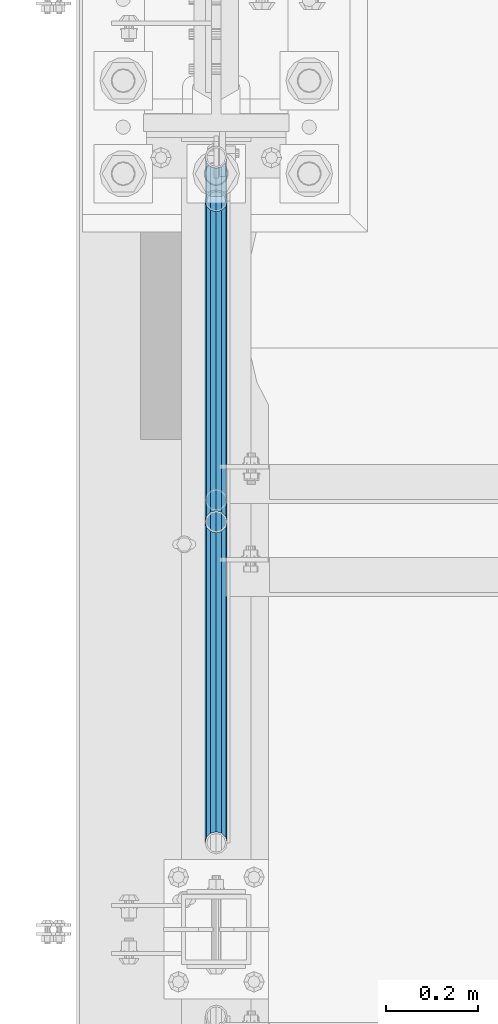
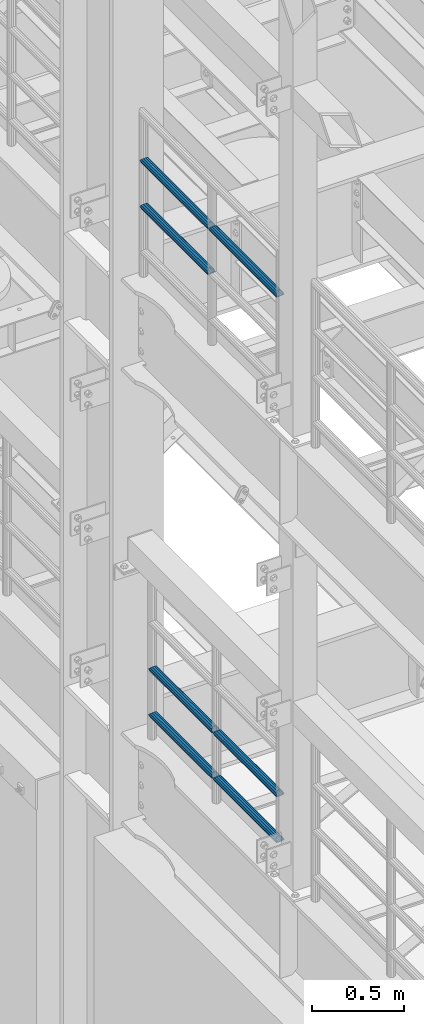
# One storey, part 1285 of 1876: 7 beams, 2 elements without a shape of their own.
"""IFC2X3 building model written with IfcOpenShell, lengths in millimetres."""

from ifc_helpers import new_model, si_unit, frame, origin_with_axes, place, context, subcontext, project, spatial, faceted_brep, material, type_object, element, aggregate, save


model = new_model("IFC2X3")

# Units and contexts
model_context = context("Model", 3, precision=1e-05, world=origin_with_axes())
body_context = subcontext(model_context, "Body", "Model", "MODEL_VIEW")
ifc_project = project(units=[si_unit("LENGTHUNIT", "METRE", prefix="MILLI"), si_unit("AREAUNIT", "SQUARE_METRE"), si_unit("VOLUMEUNIT", "CUBIC_METRE"), si_unit("MASSUNIT", "GRAM", prefix="KILO"), si_unit("TIMEUNIT", "SECOND"), si_unit("PLANEANGLEUNIT", "RADIAN"), si_unit("SOLIDANGLEUNIT", "STERADIAN"), si_unit("THERMODYNAMICTEMPERATUREUNIT", "DEGREE_CELSIUS"), si_unit("LUMINOUSINTENSITYUNIT", "LUMEN")], contexts=[model_context])

# Site, building, storey
site_placement = place(None, origin_with_axes())
site = spatial("IfcSite", under=ifc_project, at=site_placement, CompositionType="ELEMENT")
building_placement = place(site_placement, origin_with_axes())
building = spatial("IfcBuilding", under=site, at=building_placement, Name="Undefined", CompositionType="ELEMENT")
storey_placement = place(building_placement, origin_with_axes())
storey = spatial("IfcBuildingStorey", under=building, at=storey_placement, Name="Undefined", CompositionType="ELEMENT", Elevation=0.0)

# Assembly, beams
assembly_1_placement = place(storey_placement, origin_with_axes())
assembly_1 = element("IfcElementAssembly", 1, at=assembly_1_placement, inside=storey, Name="RAIL", AssemblyPlace="NOTDEFINED", PredefinedType="RIGID_FRAME")
ifc_material = material()
beam_type = type_object("IfcBeamType", Name="PIPE1-1/2SCH40", PredefinedType="NOTDEFINED")
beam_1_placement = place(assembly_1_placement, frame((-1.81898940354586e-12, 6526.2125, 8620.125), z_axis=(0.0, 0.0, -1.0), x_axis=(0.0, 1.0, 0.0)))
beam_1 = element("IfcBeam", 2, at=beam_1_placement, type_object=beam_type, material=ifc_material, Name="RAIL", ObjectType="PIPE1-1/2SCH40", context=body_context, shape_type="Brep", body=[
    faceted_brep([(0.0, 24.1299999999992, 0.0), (12.0650000000064, 20.8971929933177, -12.0649999999987), (12.0650000000064, 20.8971929933177, 12.0649999999987), (12.0650000000064, -20.8971929933177, 12.0649999999987), (12.0650000000064, -20.8971929933177, -12.0649999999987), (0.0, -24.1299999999992, 0.0), (20.8971929933249, -12.0650000000005, 20.8971929933177), (20.8971929933249, -12.0650000000005, 15.8661214311796), (15.2545715621445, -17.7076214311801, 10.2235000000001), (12.5151929933249, -20.4470000000001, 0.0), (15.2545715621445, -17.7076214311801, -10.2235000000001), (20.8971929933249, -12.0650000000005, -15.8661214311796), (20.8971929933249, -12.0650000000005, -20.8971929933177), (24.1300000000063, 0.0, -20.4470000000001), (24.1300000000063, 0.0, -24.130000000001), (21.3906214311868, -10.2235000000001, -17.7076214311819), (21.3906214311868, 10.2235000000001, -17.7076214311819), (20.8971929933249, 12.0650000000005, -15.8661214311796), (20.8971929933249, 12.0650000000005, -20.8971929933177), (15.2545715621445, 17.7076214311801, -10.2235000000001), (12.5151929933249, 20.4470000000001, 0.0), (15.2545715621445, 17.7076214311801, 10.2235000000001), (20.8971929933249, 12.0650000000005, 15.8661214311796), (20.8971929933249, 12.0650000000005, 20.8971929933177), (21.3906214311868, 10.2235000000001, 17.7076214311819), (24.1300000000064, 0.0, 20.4470000000001), (24.1300000000064, 0.0, 24.130000000001), (21.3906214311868, -10.2235000000001, 17.7076214311819), (748.982500000002, 24.1300000000001, 0.0), (736.917500000002, 20.8971929933186, -12.0649999999987), (728.085307006683, 12.0649999999996, -20.8971929933177), (748.982500000002, -24.1300000000001, 0.0), (736.917500000002, -20.8971929933186, -12.0649999999987), (736.917500000002, -20.8971929933186, 12.0649999999987), (728.085307006683, -12.0649999999996, 20.8971929933177), (728.085307006683, -12.0649999999996, -20.8971929933177), (724.852500000002, 0.0, -24.130000000001), (727.591878568821, 10.2235000000001, -17.7076214311819), (724.852500000002, 0.0, -20.4470000000001), (728.085307006683, 12.0649999999996, -15.8661214311796), (728.085307006683, -12.0649999999996, -15.8661214311796), (727.591878568821, -10.2235000000001, -17.7076214311819), (733.727928437864, -17.7076214311801, -10.2235000000001), (736.467307006683, -20.4470000000001, 0.0), (733.727928437864, -17.7076214311801, 10.2235000000001), (728.085307006683, -12.0649999999996, 15.8661214311796), (727.591878568821, -10.2235000000001, 17.7076214311819), (724.852500000002, 0.0, 20.4470000000001), (724.852500000002, 0.0, 24.130000000001), (728.085307006683, 12.0649999999996, 20.8971929933177), (736.917500000002, 20.8971929933186, 12.0649999999987), (728.085307006683, 12.0649999999996, 15.8661214311796), (733.727928437864, 17.7076214311801, 10.2235000000001), (736.467307006683, 20.4470000000001, 0.0), (733.727928437864, 17.7076214311801, -10.2235000000001), (727.591878568821, 10.2235000000001, 17.7076214311819)], [[[0, 1, 2]], [[3, 4, 5]], [[6, 7, 8, 9, 10, 11, 12, 4, 3]], [[13, 14, 12, 11, 15]], [[16, 17, 18, 14, 13]], [[2, 1, 18, 17, 19, 20, 21, 22, 23]], [[23, 22, 24, 25, 26]], [[26, 25, 27, 7, 6]], [[1, 0, 28, 29]], [[18, 1, 29, 30]], [[31, 32, 33]], [[6, 3, 33, 34]], [[3, 5, 31, 33]], [[5, 4, 32, 31]], [[4, 12, 35, 32]], [[12, 14, 36, 35]], [[14, 18, 30, 36]], [[37, 38, 36, 30, 39]], [[40, 35, 36, 38, 41]], [[33, 32, 35, 40, 42, 43, 44, 45, 34]], [[34, 45, 46, 47, 48]], [[26, 6, 34, 48]], [[2, 23, 49, 50]], [[23, 26, 48, 49]], [[0, 2, 50, 28]], [[28, 50, 29]], [[49, 51, 52, 53, 54, 39, 30, 29, 50]], [[48, 47, 55, 51, 49]], [[25, 24, 55, 47]], [[55, 24, 22, 21, 52, 51]], [[21, 20, 53, 52]], [[20, 19, 54, 53]], [[19, 17, 16, 37, 39, 54]], [[16, 13, 38, 37]], [[13, 15, 41, 38]], [[41, 15, 11, 10, 42, 40]], [[10, 9, 43, 42]], [[9, 8, 44, 43]], [[8, 7, 27, 46, 45, 44]], [[27, 25, 47, 46]]]),
])
beam_2_placement = place(assembly_1_placement, frame((-1.81898940354586e-12, 5777.23, 8924.925), z_axis=(0.0, 0.0, -1.0), x_axis=(0.0, 1.0, 0.0)))
beam_2 = element("IfcBeam", 3, at=beam_2_placement, type_object=beam_type, material=ifc_material, Name="RAIL", ObjectType="PIPE1-1/2SCH40", context=body_context, shape_type="Brep", body=[
    faceted_brep([(0.0, 24.1299999999992, 0.0), (12.0650000000064, 20.8971929933177, -12.0649999999987), (12.0650000000064, 20.8971929933177, 12.0649999999987), (12.0650000000064, -20.8971929933177, 12.0649999999987), (12.0650000000064, -20.8971929933177, -12.0649999999987), (0.0, -24.1299999999992, 0.0), (20.8971929933249, -12.0650000000005, 20.8971929933177), (20.8971929933249, -12.0650000000005, 15.8661214311796), (15.2545715621445, -17.7076214311801, 10.2235000000001), (12.5151929933249, -20.4470000000001, 0.0), (15.2545715621445, -17.7076214311801, -10.2235000000001), (20.8971929933249, -12.0650000000005, -15.8661214311796), (20.8971929933249, -12.0650000000005, -20.8971929933177), (24.1300000000063, 0.0, -20.4470000000001), (24.1300000000063, 0.0, -24.130000000001), (21.3906214311868, -10.2235000000001, -17.7076214311819), (21.3906214311868, 10.2235000000001, -17.7076214311819), (20.8971929933249, 12.0650000000005, -15.8661214311796), (20.8971929933249, 12.0650000000005, -20.8971929933177), (15.2545715621445, 17.7076214311801, -10.2235000000001), (12.5151929933249, 20.4470000000001, 0.0), (15.2545715621445, 17.7076214311801, 10.2235000000001), (20.8971929933249, 12.0650000000005, 15.8661214311796), (20.8971929933249, 12.0650000000005, 20.8971929933177), (21.3906214311868, 10.2235000000001, 17.7076214311819), (24.1300000000064, 0.0, 20.4470000000001), (24.1300000000064, 0.0, 24.130000000001), (21.3906214311868, -10.2235000000001, 17.7076214311819), (748.982500000002, 24.1300000000001, 0.0), (736.917500000002, 20.8971929933186, -12.0649999999987), (728.085307006683, 12.0649999999996, -20.8971929933177), (748.982500000002, -24.1300000000001, 0.0), (736.917500000002, -20.8971929933186, -12.0649999999987), (736.917500000002, -20.8971929933186, 12.0649999999987), (728.085307006683, -12.0649999999996, 20.8971929933177), (728.085307006683, -12.0649999999996, -20.8971929933177), (724.852500000002, 0.0, -24.130000000001), (727.591878568821, 10.2235000000001, -17.7076214311819), (724.852500000002, 0.0, -20.4470000000001), (728.085307006683, 12.0649999999996, -15.8661214311796), (728.085307006683, -12.0649999999996, -15.8661214311796), (727.591878568821, -10.2235000000001, -17.7076214311819), (733.727928437864, -17.7076214311801, -10.2235000000001), (736.467307006683, -20.4470000000001, 0.0), (733.727928437864, -17.7076214311801, 10.2235000000001), (728.085307006683, -12.0649999999996, 15.8661214311796), (727.591878568821, -10.2235000000001, 17.7076214311819), (724.852500000002, 0.0, 20.4470000000001), (724.852500000002, 0.0, 24.130000000001), (728.085307006683, 12.0649999999996, 20.8971929933177), (736.917500000002, 20.8971929933186, 12.0649999999987), (728.085307006683, 12.0649999999996, 15.8661214311796), (733.727928437864, 17.7076214311801, 10.2235000000001), (736.467307006683, 20.4470000000001, 0.0), (733.727928437864, 17.7076214311801, -10.2235000000001), (727.591878568821, 10.2235000000001, 17.7076214311819)], [[[0, 1, 2]], [[3, 4, 5]], [[6, 7, 8, 9, 10, 11, 12, 4, 3]], [[13, 14, 12, 11, 15]], [[16, 17, 18, 14, 13]], [[2, 1, 18, 17, 19, 20, 21, 22, 23]], [[23, 22, 24, 25, 26]], [[26, 25, 27, 7, 6]], [[1, 0, 28, 29]], [[18, 1, 29, 30]], [[31, 32, 33]], [[6, 3, 33, 34]], [[3, 5, 31, 33]], [[5, 4, 32, 31]], [[4, 12, 35, 32]], [[12, 14, 36, 35]], [[14, 18, 30, 36]], [[37, 38, 36, 30, 39]], [[40, 35, 36, 38, 41]], [[33, 32, 35, 40, 42, 43, 44, 45, 34]], [[34, 45, 46, 47, 48]], [[26, 6, 34, 48]], [[2, 23, 49, 50]], [[23, 26, 48, 49]], [[0, 2, 50, 28]], [[28, 50, 29]], [[49, 51, 52, 53, 54, 39, 30, 29, 50]], [[48, 47, 55, 51, 49]], [[25, 24, 55, 47]], [[55, 24, 22, 21, 52, 51]], [[21, 20, 53, 52]], [[20, 19, 54, 53]], [[19, 17, 16, 37, 39, 54]], [[16, 13, 38, 37]], [[13, 15, 41, 38]], [[41, 15, 11, 10, 42, 40]], [[10, 9, 43, 42]], [[9, 8, 44, 43]], [[8, 7, 27, 46, 45, 44]], [[27, 25, 47, 46]]]),
])
beam_3_placement = place(assembly_1_placement, frame((-1.81898940354586e-12, 6526.2125, 8924.925), z_axis=(0.0, 0.0, -1.0), x_axis=(0.0, 1.0, 0.0)))
beam_3 = element("IfcBeam", 4, at=beam_3_placement, type_object=beam_type, material=ifc_material, Name="RAIL", ObjectType="PIPE1-1/2SCH40", context=body_context, shape_type="Brep", body=[
    faceted_brep([(0.0, 24.1299999999992, 0.0), (12.0650000000064, 20.8971929933177, -12.0649999999987), (12.0650000000064, 20.8971929933177, 12.0649999999987), (12.0650000000064, -20.8971929933177, 12.0649999999987), (12.0650000000064, -20.8971929933177, -12.0649999999987), (0.0, -24.1299999999992, 0.0), (20.8971929933249, -12.0650000000005, 20.8971929933177), (20.8971929933249, -12.0650000000005, 15.8661214311796), (15.2545715621445, -17.7076214311801, 10.2235000000001), (12.5151929933249, -20.4470000000001, 0.0), (15.2545715621445, -17.7076214311801, -10.2235000000001), (20.8971929933249, -12.0650000000005, -15.8661214311796), (20.8971929933249, -12.0650000000005, -20.8971929933177), (24.1300000000063, 0.0, -20.4470000000001), (24.1300000000063, 0.0, -24.130000000001), (21.3906214311868, -10.2235000000001, -17.7076214311819), (21.3906214311868, 10.2235000000001, -17.7076214311819), (20.8971929933249, 12.0650000000005, -15.8661214311796), (20.8971929933249, 12.0650000000005, -20.8971929933177), (15.2545715621445, 17.7076214311801, -10.2235000000001), (12.5151929933249, 20.4470000000001, 0.0), (15.2545715621445, 17.7076214311801, 10.2235000000001), (20.8971929933249, 12.0650000000005, 15.8661214311796), (20.8971929933249, 12.0650000000005, 20.8971929933177), (21.3906214311868, 10.2235000000001, 17.7076214311819), (24.1300000000064, 0.0, 20.4470000000001), (24.1300000000064, 0.0, 24.130000000001), (21.3906214311868, -10.2235000000001, 17.7076214311819), (748.982500000002, 24.1300000000001, 0.0), (736.917500000002, 20.8971929933186, -12.0649999999987), (728.085307006683, 12.0649999999996, -20.8971929933177), (748.982500000002, -24.1300000000001, 0.0), (736.917500000002, -20.8971929933186, -12.0649999999987), (736.917500000002, -20.8971929933186, 12.0649999999987), (728.085307006683, -12.0649999999996, 20.8971929933177), (728.085307006683, -12.0649999999996, -20.8971929933177), (724.852500000002, 0.0, -24.130000000001), (727.591878568821, 10.2235000000001, -17.7076214311819), (724.852500000002, 0.0, -20.4470000000001), (728.085307006683, 12.0649999999996, -15.8661214311796), (728.085307006683, -12.0649999999996, -15.8661214311796), (727.591878568821, -10.2235000000001, -17.7076214311819), (733.727928437864, -17.7076214311801, -10.2235000000001), (736.467307006683, -20.4470000000001, 0.0), (733.727928437864, -17.7076214311801, 10.2235000000001), (728.085307006683, -12.0649999999996, 15.8661214311796), (727.591878568821, -10.2235000000001, 17.7076214311819), (724.852500000002, 0.0, 20.4470000000001), (724.852500000002, 0.0, 24.130000000001), (728.085307006683, 12.0649999999996, 20.8971929933177), (736.917500000002, 20.8971929933186, 12.0649999999987), (728.085307006683, 12.0649999999996, 15.8661214311796), (733.727928437864, 17.7076214311801, 10.2235000000001), (736.467307006683, 20.4470000000001, 0.0), (733.727928437864, 17.7076214311801, -10.2235000000001), (727.591878568821, 10.2235000000001, 17.7076214311819)], [[[0, 1, 2]], [[3, 4, 5]], [[6, 7, 8, 9, 10, 11, 12, 4, 3]], [[13, 14, 12, 11, 15]], [[16, 17, 18, 14, 13]], [[2, 1, 18, 17, 19, 20, 21, 22, 23]], [[23, 22, 24, 25, 26]], [[26, 25, 27, 7, 6]], [[1, 0, 28, 29]], [[18, 1, 29, 30]], [[31, 32, 33]], [[6, 3, 33, 34]], [[3, 5, 31, 33]], [[5, 4, 32, 31]], [[4, 12, 35, 32]], [[12, 14, 36, 35]], [[14, 18, 30, 36]], [[37, 38, 36, 30, 39]], [[40, 35, 36, 38, 41]], [[33, 32, 35, 40, 42, 43, 44, 45, 34]], [[34, 45, 46, 47, 48]], [[26, 6, 34, 48]], [[2, 23, 49, 50]], [[23, 26, 48, 49]], [[0, 2, 50, 28]], [[28, 50, 29]], [[49, 51, 52, 53, 54, 39, 30, 29, 50]], [[48, 47, 55, 51, 49]], [[25, 24, 55, 47]], [[55, 24, 22, 21, 52, 51]], [[21, 20, 53, 52]], [[20, 19, 54, 53]], [[19, 17, 16, 37, 39, 54]], [[16, 13, 38, 37]], [[13, 15, 41, 38]], [[41, 15, 11, 10, 42, 40]], [[10, 9, 43, 42]], [[9, 8, 44, 43]], [[8, 7, 27, 46, 45, 44]], [[27, 25, 47, 46]]]),
])
aggregate(assembly_1, [beam_1, beam_2, beam_3])

assembly_2_placement = place(storey_placement, origin_with_axes())
assembly_2 = element("IfcElementAssembly", 5, at=assembly_2_placement, inside=storey, Name="RAIL", AssemblyPlace="NOTDEFINED", PredefinedType="RIGID_FRAME")
beam_4_placement = place(assembly_2_placement, frame((7.02584657119587e-11, 6478.5698316807, 5292.73091229414), z_axis=(0.0, -8.42999999986204e-06, 0.999999999964468), x_axis=(0.0, 0.999999999964468, 8.43000000018809e-06)))
beam_4 = element("IfcBeam", 6, at=beam_4_placement, type_object=beam_type, material=ifc_material, Name="RAIL", ObjectType="PIPE1-1/2SCH40", context=body_context, shape_type="Brep", body=[
    faceted_brep([(680.442814874983, -12.0649999999996, 20.8971929933068), (680.44277246305, -12.0649999999277, 15.8661214312397), (679.949359549034, -10.2235000000001, 17.7076214311674), (677.210004073059, 2.72848410531878e-12, 20.4469999999883), (677.210035120749, 2.72848410531878e-12, 24.1299999999883), (679.949359548996, 10.2235000000001, 17.7076214311674), (680.44277246305, 12.0650000000714, 15.866121431096), (680.442814874983, 12.0649999999996, 20.8971929933068), (701.33983170571, 24.1300000000001, -1.45519152283669e-11), (689.27493341323, 20.8971929933186, 12.0649999999878), (689.27472999733, 20.8971929933186, -12.0650000000151), (686.085346327061, 17.7076214311801, 10.2234999999873), (688.824638711873, 20.4470000000001, -1.36424205265939e-11), (686.085173958852, 17.7076214311801, -10.2235000000137), (680.442504960242, 12.0650000000714, -15.8661214311223), (680.442462548309, 12.0649999999996, -20.8971929933323), (679.949060998498, 10.2235000000001, -17.7076214311946), (677.20965933664, 0.0, -20.4470000000147), (677.20962828895, 0.0, -24.1300000000147), (680.442504960242, -12.0649999999277, -15.866121431266), (680.442462548309, -12.0649999999996, -20.8971929933323), (679.949060998536, -10.2235000000001, -17.7076214311946), (701.33983170571, -24.1299999999283, -1.45519152283669e-11), (689.27472999733, -20.8971929933186, -12.0650000000151), (689.27493341323, -20.8971929933186, 12.0649999999878), (686.085173958994, -17.7076214311801, -10.2235000000137), (688.824638712016, -20.4470000000001, -1.36424205265939e-11), (686.085346327204, -17.7076214311801, 10.2234999999873), (12.0648982924813, -20.8971929933186, -12.0650000000005), (20.8970168307269, -12.0649999999996, -20.8971929933195), (0.0, 24.1299999999992, 0.0), (12.0648982924813, 20.8971929933186, -12.0650000000005), (12.065101708381, 20.8971929933186, 12.0650000000005), (20.897369157401, 12.0649999999996, 20.8971929933205), (24.1302034167611, 7.18500814400613e-11, 24.1300000000019), (20.8970168307269, 12.0649999999996, -20.8971929933195), (24.1297965849608, 0.0, -24.130000000001), (24.1298276326506, 0.0, -20.447000000001), (20.8970592426604, -12.0649999999277, -15.8661214312533), (21.390472156676, -10.2235000000001, -17.7076214311819), (21.3904721567151, 10.2235000000001, -17.7076214311819), (20.8970592426604, 12.0650000000714, -15.8661214311096), (15.2544853786503, 17.7076214311801, -10.2235000000001), (12.5151929933249, 20.4470000000001, 0.0), (15.2546577468602, 17.7076214311801, 10.223500000001), (20.8973267454676, 12.0650000000714, 15.8661214311096), (21.3907707072121, 10.2235000000001, 17.7076214311819), (24.1301723690713, 7.18500814400613e-11, 20.447000000001), (21.390770707173, -10.2235000000001, 17.7076214311819), (20.8973267454676, -12.0649999999277, 15.8661214312533), (20.897369157401, -12.0649999999996, 20.8971929933205), (12.065101708381, -20.8971929933186, 12.0650000000005), (0.0, -24.1299999999992, 0.0), (15.2546577467156, -17.7076214311801, 10.223500000001), (12.5151929933249, -20.4470000000001, 0.0), (15.2544853785057, -17.7076214311801, -10.2235000000001)], [[[0, 1, 2, 3, 4]], [[4, 3, 5, 6, 7]], [[8, 9, 10]], [[7, 6, 11, 12, 13, 14, 15, 10, 9]], [[16, 17, 18, 15, 14]], [[19, 20, 18, 17, 21]], [[22, 23, 24]], [[24, 23, 20, 19, 25, 26, 27, 1, 0]], [[28, 29, 20, 23]], [[30, 31, 32]], [[33, 34, 4, 7]], [[32, 33, 7, 9]], [[30, 32, 9, 8]], [[31, 30, 8, 10]], [[35, 31, 10, 15]], [[36, 35, 15, 18]], [[29, 36, 18, 20]], [[37, 36, 29, 38, 39]], [[40, 41, 35, 36, 37]], [[32, 31, 35, 41, 42, 43, 44, 45, 33]], [[33, 45, 46, 47, 34]], [[34, 47, 48, 49, 50]], [[34, 50, 0, 4]], [[50, 51, 24, 0]], [[51, 52, 22, 24]], [[52, 28, 23, 22]], [[51, 28, 52]], [[50, 49, 53, 54, 55, 38, 29, 28, 51]], [[55, 54, 26, 25]], [[21, 39, 38, 55, 25, 19]], [[37, 39, 21, 17]], [[40, 37, 17, 16]], [[42, 41, 40, 16, 14, 13]], [[43, 42, 13, 12]], [[44, 43, 12, 11]], [[5, 46, 45, 44, 11, 6]], [[47, 46, 5, 3]], [[48, 47, 3, 2]], [[53, 49, 48, 2, 1, 27]], [[54, 53, 27, 26]]]),
])
beam_5_placement = place(assembly_2_placement, frame((1.71398992221405e-10, 5777.23, 5292.72499999952), z_axis=(0.0, -8.42999999986204e-06, 0.999999999964468), x_axis=(0.0, 0.999999999964468, 8.43000000018809e-06)))
beam_5 = element("IfcBeam", 7, at=beam_5_placement, type_object=beam_type, material=ifc_material, Name="RAIL", ObjectType="PIPE1-1/2SCH40", context=body_context, shape_type="Brep", body=[
    faceted_brep([(680.442814874983, -12.0649999999996, 20.8971929933068), (680.44277246305, -12.0649999999277, 15.8661214312397), (679.949359549034, -10.2235000000001, 17.7076214311674), (677.210004073059, 2.72848410531878e-12, 20.4469999999883), (677.210035120749, 2.72848410531878e-12, 24.1299999999883), (679.949359548996, 10.2235000000001, 17.7076214311674), (680.44277246305, 12.0650000000714, 15.866121431096), (680.442814874983, 12.0649999999996, 20.8971929933068), (701.33983170571, 24.1300000000001, -1.45519152283669e-11), (689.27493341323, 20.8971929933186, 12.0649999999878), (689.27472999733, 20.8971929933186, -12.0650000000151), (686.085346327061, 17.7076214311801, 10.2234999999873), (688.824638711873, 20.4470000000001, -1.36424205265939e-11), (686.085173958852, 17.7076214311801, -10.2235000000137), (680.442504960242, 12.0650000000714, -15.8661214311223), (680.442462548309, 12.0649999999996, -20.8971929933323), (679.949060998498, 10.2235000000001, -17.7076214311946), (677.20965933664, 0.0, -20.4470000000147), (677.20962828895, 0.0, -24.1300000000147), (680.442504960242, -12.0649999999277, -15.866121431266), (680.442462548309, -12.0649999999996, -20.8971929933323), (679.949060998536, -10.2235000000001, -17.7076214311946), (701.33983170571, -24.1299999999283, -1.45519152283669e-11), (689.27472999733, -20.8971929933186, -12.0650000000151), (689.27493341323, -20.8971929933186, 12.0649999999878), (686.085173958994, -17.7076214311801, -10.2235000000137), (688.824638712016, -20.4470000000001, -1.36424205265939e-11), (686.085346327204, -17.7076214311801, 10.2234999999873), (12.0648982924813, -20.8971929933186, -12.0650000000005), (20.8970168307269, -12.0649999999996, -20.8971929933195), (0.0, 24.1299999999992, 0.0), (12.0648982924813, 20.8971929933186, -12.0650000000005), (12.065101708381, 20.8971929933186, 12.0650000000005), (20.897369157401, 12.0649999999996, 20.8971929933205), (24.1302034167611, 7.18500814400613e-11, 24.1300000000019), (20.8970168307269, 12.0649999999996, -20.8971929933195), (24.1297965849608, 0.0, -24.130000000001), (24.1298276326506, 0.0, -20.447000000001), (20.8970592426604, -12.0649999999277, -15.8661214312533), (21.390472156676, -10.2235000000001, -17.7076214311819), (21.3904721567151, 10.2235000000001, -17.7076214311819), (20.8970592426604, 12.0650000000714, -15.8661214311096), (15.2544853786503, 17.7076214311801, -10.2235000000001), (12.5151929933249, 20.4470000000001, 0.0), (15.2546577468602, 17.7076214311801, 10.223500000001), (20.8973267454676, 12.0650000000714, 15.8661214311096), (21.3907707072121, 10.2235000000001, 17.7076214311819), (24.1301723690713, 7.18500814400613e-11, 20.447000000001), (21.390770707173, -10.2235000000001, 17.7076214311819), (20.8973267454676, -12.0649999999277, 15.8661214312533), (20.897369157401, -12.0649999999996, 20.8971929933205), (12.065101708381, -20.8971929933186, 12.0650000000005), (0.0, -24.1299999999992, 0.0), (15.2546577467156, -17.7076214311801, 10.223500000001), (12.5151929933249, -20.4470000000001, 0.0), (15.2544853785057, -17.7076214311801, -10.2235000000001)], [[[0, 1, 2, 3, 4]], [[4, 3, 5, 6, 7]], [[8, 9, 10]], [[7, 6, 11, 12, 13, 14, 15, 10, 9]], [[16, 17, 18, 15, 14]], [[19, 20, 18, 17, 21]], [[22, 23, 24]], [[24, 23, 20, 19, 25, 26, 27, 1, 0]], [[28, 29, 20, 23]], [[30, 31, 32]], [[33, 34, 4, 7]], [[32, 33, 7, 9]], [[30, 32, 9, 8]], [[31, 30, 8, 10]], [[35, 31, 10, 15]], [[36, 35, 15, 18]], [[29, 36, 18, 20]], [[37, 36, 29, 38, 39]], [[40, 41, 35, 36, 37]], [[32, 31, 35, 41, 42, 43, 44, 45, 33]], [[33, 45, 46, 47, 34]], [[34, 47, 48, 49, 50]], [[34, 50, 0, 4]], [[50, 51, 24, 0]], [[51, 52, 22, 24]], [[52, 28, 23, 22]], [[51, 28, 52]], [[50, 49, 53, 54, 55, 38, 29, 28, 51]], [[55, 54, 26, 25]], [[21, 39, 38, 55, 25, 19]], [[37, 39, 21, 17]], [[40, 37, 17, 16]], [[42, 41, 40, 16, 14, 13]], [[43, 42, 13, 12]], [[44, 43, 12, 11]], [[5, 46, 45, 44, 11, 6]], [[47, 46, 5, 3]], [[48, 47, 3, 2]], [[53, 49, 48, 2, 1, 27]], [[54, 53, 27, 26]]]),
])
beam_6_placement = place(assembly_2_placement, frame((3.1513991416432e-10, 7179.9096633614, 5597.53682459919), z_axis=(0.0, 7.91400000045761e-06, -0.999999999968684), x_axis=(0.0, -0.999999999968684, -7.91400000071008e-06)))
beam_6 = element("IfcBeam", 8, at=beam_6_placement, type_object=beam_type, material=ifc_material, Name="RAIL", ObjectType="PIPE1-1/2SCH40", context=body_context, shape_type="Brep", body=[
    faceted_brep([(0.0, 24.1299999999992, 0.0), (12.0648982924813, 20.8971929933186, -12.0650000000005), (12.065101708381, 20.8971929933186, 12.0650000000005), (12.065101708381, -20.8971929933186, 12.0650000000005), (12.0648982924813, -20.8971929933186, -12.0650000000005), (0.0, -24.1299999999992, 0.0), (20.897369157401, -12.0649999999996, 20.8971929933205), (20.8973267454676, -12.0649999999277, 15.8661214312533), (15.2546577467156, -17.7076214311801, 10.223500000001), (12.5151929933249, -20.4470000000001, 0.0), (15.2544853785057, -17.7076214311801, -10.2235000000001), (20.8970592426604, -12.0649999999277, -15.8661214312533), (20.8970168307269, -12.0649999999996, -20.8971929933195), (24.1298276326506, 0.0, -20.447000000001), (24.1297965849608, 0.0, -24.130000000001), (21.390472156676, -10.2235000000001, -17.7076214311819), (21.3904721567151, 10.2235000000001, -17.7076214311819), (20.8970592426604, 12.0650000000714, -15.8661214311096), (20.8970168307269, 12.0649999999996, -20.8971929933195), (15.2544853786503, 17.7076214311801, -10.2235000000001), (12.5151929933249, 20.4470000000001, 0.0), (15.2546577468602, 17.7076214311801, 10.223500000001), (20.8973267454676, 12.0650000000714, 15.8661214311096), (20.897369157401, 12.0649999999996, 20.8971929933205), (21.3907707072121, 10.2235000000001, 17.7076214311819), (24.1301723690713, 7.18500814400613e-11, 20.447000000001), (24.1302034167611, 7.18500814400613e-11, 24.1300000000019), (21.390770707173, -10.2235000000001, 17.7076214311819), (701.33983170571, 24.1300000000001, -1.45519152283669e-11), (689.27472999733, 20.8971929933186, -12.0650000000151), (680.442462548309, 12.0649999999996, -20.8971929933323), (701.33983170571, -24.1299999999283, -1.45519152283669e-11), (689.27472999733, -20.8971929933186, -12.0650000000151), (689.27493341323, -20.8971929933186, 12.0649999999878), (680.442814874983, -12.0649999999996, 20.8971929933068), (680.442462548309, -12.0649999999996, -20.8971929933323), (677.20962828895, 0.0, -24.1300000000147), (679.949060998498, 10.2235000000001, -17.7076214311946), (677.20965933664, 0.0, -20.4470000000147), (680.442504960242, 12.0650000000714, -15.8661214311223), (680.442504960242, -12.0649999999277, -15.866121431266), (679.949060998536, -10.2235000000001, -17.7076214311946), (686.085173958994, -17.7076214311801, -10.2235000000137), (688.824638712016, -20.4470000000001, -1.36424205265939e-11), (686.085346327204, -17.7076214311801, 10.2234999999873), (680.44277246305, -12.0649999999277, 15.8661214312397), (679.949359549034, -10.2235000000001, 17.7076214311674), (677.210004073059, 2.72848410531878e-12, 20.4469999999883), (677.210035120749, 2.72848410531878e-12, 24.1299999999883), (680.442814874983, 12.0649999999996, 20.8971929933068), (689.27493341323, 20.8971929933186, 12.0649999999878), (680.44277246305, 12.0650000000714, 15.866121431096), (686.085346327061, 17.7076214311801, 10.2234999999873), (688.824638711873, 20.4470000000001, -1.36424205265939e-11), (686.085173958852, 17.7076214311801, -10.2235000000137), (679.949359548996, 10.2235000000001, 17.7076214311674)], [[[0, 1, 2]], [[3, 4, 5]], [[6, 7, 8, 9, 10, 11, 12, 4, 3]], [[13, 14, 12, 11, 15]], [[16, 17, 18, 14, 13]], [[2, 1, 18, 17, 19, 20, 21, 22, 23]], [[23, 22, 24, 25, 26]], [[26, 25, 27, 7, 6]], [[1, 0, 28, 29]], [[18, 1, 29, 30]], [[31, 32, 33]], [[6, 3, 33, 34]], [[3, 5, 31, 33]], [[5, 4, 32, 31]], [[4, 12, 35, 32]], [[12, 14, 36, 35]], [[14, 18, 30, 36]], [[37, 38, 36, 30, 39]], [[40, 35, 36, 38, 41]], [[33, 32, 35, 40, 42, 43, 44, 45, 34]], [[34, 45, 46, 47, 48]], [[26, 6, 34, 48]], [[2, 23, 49, 50]], [[23, 26, 48, 49]], [[0, 2, 50, 28]], [[28, 50, 29]], [[49, 51, 52, 53, 54, 39, 30, 29, 50]], [[48, 47, 55, 51, 49]], [[25, 24, 55, 47]], [[55, 24, 22, 21, 52, 51]], [[21, 20, 53, 52]], [[20, 19, 54, 53]], [[19, 17, 16, 37, 39, 54]], [[16, 13, 38, 37]], [[13, 15, 41, 38]], [[41, 15, 11, 10, 42, 40]], [[10, 9, 43, 42]], [[9, 8, 44, 43]], [[8, 7, 27, 46, 45, 44]], [[27, 25, 47, 46]]]),
])
beam_7_placement = place(assembly_2_placement, frame((7.03721525496803e-11, 6478.5698316807, 5597.53091229414), z_axis=(0.0, 7.91400000045761e-06, -0.999999999968684), x_axis=(0.0, -0.999999999968684, -7.91400000071008e-06)))
beam_7 = element("IfcBeam", 9, at=beam_7_placement, type_object=beam_type, material=ifc_material, Name="RAIL", ObjectType="PIPE1-1/2SCH40", context=body_context, shape_type="Brep", body=[
    faceted_brep([(0.0, 24.1299999999992, 0.0), (12.0648982924813, 20.8971929933186, -12.0650000000005), (12.065101708381, 20.8971929933186, 12.0650000000005), (12.065101708381, -20.8971929933186, 12.0650000000005), (12.0648982924813, -20.8971929933186, -12.0650000000005), (0.0, -24.1299999999992, 0.0), (20.897369157401, -12.0649999999996, 20.8971929933205), (20.8973267454676, -12.0649999999277, 15.8661214312533), (15.2546577467156, -17.7076214311801, 10.223500000001), (12.5151929933249, -20.4470000000001, 0.0), (15.2544853785057, -17.7076214311801, -10.2235000000001), (20.8970592426604, -12.0649999999277, -15.8661214312533), (20.8970168307269, -12.0649999999996, -20.8971929933195), (24.1298276326506, 0.0, -20.447000000001), (24.1297965849608, 0.0, -24.130000000001), (21.390472156676, -10.2235000000001, -17.7076214311819), (21.3904721567151, 10.2235000000001, -17.7076214311819), (20.8970592426604, 12.0650000000714, -15.8661214311096), (20.8970168307269, 12.0649999999996, -20.8971929933195), (15.2544853786503, 17.7076214311801, -10.2235000000001), (12.5151929933249, 20.4470000000001, 0.0), (15.2546577468602, 17.7076214311801, 10.223500000001), (20.8973267454676, 12.0650000000714, 15.8661214311096), (20.897369157401, 12.0649999999996, 20.8971929933205), (21.3907707072121, 10.2235000000001, 17.7076214311819), (24.1301723690713, 7.18500814400613e-11, 20.447000000001), (24.1302034167611, 7.18500814400613e-11, 24.1300000000019), (21.390770707173, -10.2235000000001, 17.7076214311819), (701.33983170571, 24.1300000000001, -1.45519152283669e-11), (689.27472999733, 20.8971929933186, -12.0650000000151), (680.442462548309, 12.0649999999996, -20.8971929933323), (701.33983170571, -24.1299999999283, -1.45519152283669e-11), (689.27472999733, -20.8971929933186, -12.0650000000151), (689.27493341323, -20.8971929933186, 12.0649999999878), (680.442814874983, -12.0649999999996, 20.8971929933068), (680.442462548309, -12.0649999999996, -20.8971929933323), (677.20962828895, 0.0, -24.1300000000147), (679.949060998498, 10.2235000000001, -17.7076214311946), (677.20965933664, 0.0, -20.4470000000147), (680.442504960242, 12.0650000000714, -15.8661214311223), (680.442504960242, -12.0649999999277, -15.866121431266), (679.949060998536, -10.2235000000001, -17.7076214311946), (686.085173958994, -17.7076214311801, -10.2235000000137), (688.824638712016, -20.4470000000001, -1.36424205265939e-11), (686.085346327204, -17.7076214311801, 10.2234999999873), (680.44277246305, -12.0649999999277, 15.8661214312397), (679.949359549034, -10.2235000000001, 17.7076214311674), (677.210004073059, 2.72848410531878e-12, 20.4469999999883), (677.210035120749, 2.72848410531878e-12, 24.1299999999883), (680.442814874983, 12.0649999999996, 20.8971929933068), (689.27493341323, 20.8971929933186, 12.0649999999878), (680.44277246305, 12.0650000000714, 15.866121431096), (686.085346327061, 17.7076214311801, 10.2234999999873), (688.824638711873, 20.4470000000001, -1.36424205265939e-11), (686.085173958852, 17.7076214311801, -10.2235000000137), (679.949359548996, 10.2235000000001, 17.7076214311674)], [[[0, 1, 2]], [[3, 4, 5]], [[6, 7, 8, 9, 10, 11, 12, 4, 3]], [[13, 14, 12, 11, 15]], [[16, 17, 18, 14, 13]], [[2, 1, 18, 17, 19, 20, 21, 22, 23]], [[23, 22, 24, 25, 26]], [[26, 25, 27, 7, 6]], [[1, 0, 28, 29]], [[18, 1, 29, 30]], [[31, 32, 33]], [[6, 3, 33, 34]], [[3, 5, 31, 33]], [[5, 4, 32, 31]], [[4, 12, 35, 32]], [[12, 14, 36, 35]], [[14, 18, 30, 36]], [[37, 38, 36, 30, 39]], [[40, 35, 36, 38, 41]], [[33, 32, 35, 40, 42, 43, 44, 45, 34]], [[34, 45, 46, 47, 48]], [[26, 6, 34, 48]], [[2, 23, 49, 50]], [[23, 26, 48, 49]], [[0, 2, 50, 28]], [[28, 50, 29]], [[49, 51, 52, 53, 54, 39, 30, 29, 50]], [[48, 47, 55, 51, 49]], [[25, 24, 55, 47]], [[55, 24, 22, 21, 52, 51]], [[21, 20, 53, 52]], [[20, 19, 54, 53]], [[19, 17, 16, 37, 39, 54]], [[16, 13, 38, 37]], [[13, 15, 41, 38]], [[41, 15, 11, 10, 42, 40]], [[10, 9, 43, 42]], [[9, 8, 44, 43]], [[8, 7, 27, 46, 45, 44]], [[27, 25, 47, 46]]]),
])
aggregate(assembly_2, [beam_4, beam_5, beam_6, beam_7])

save(model, "model.ifc")
